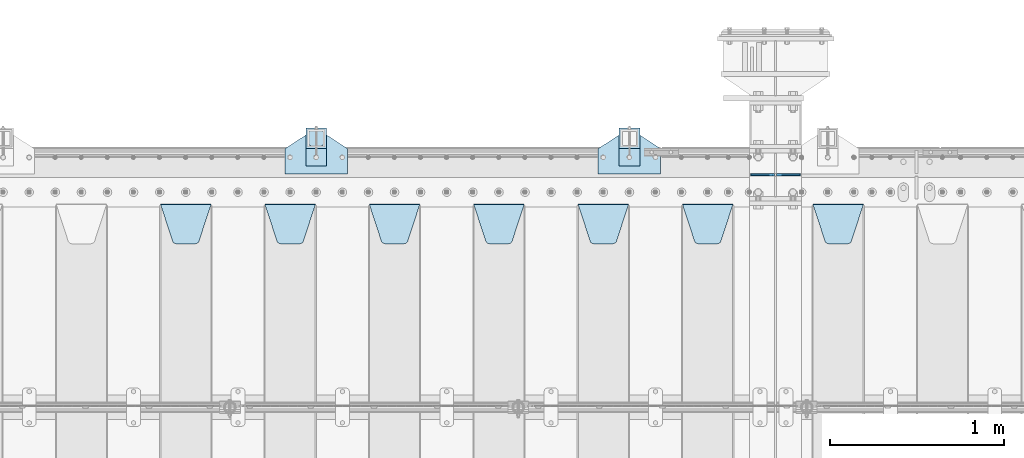
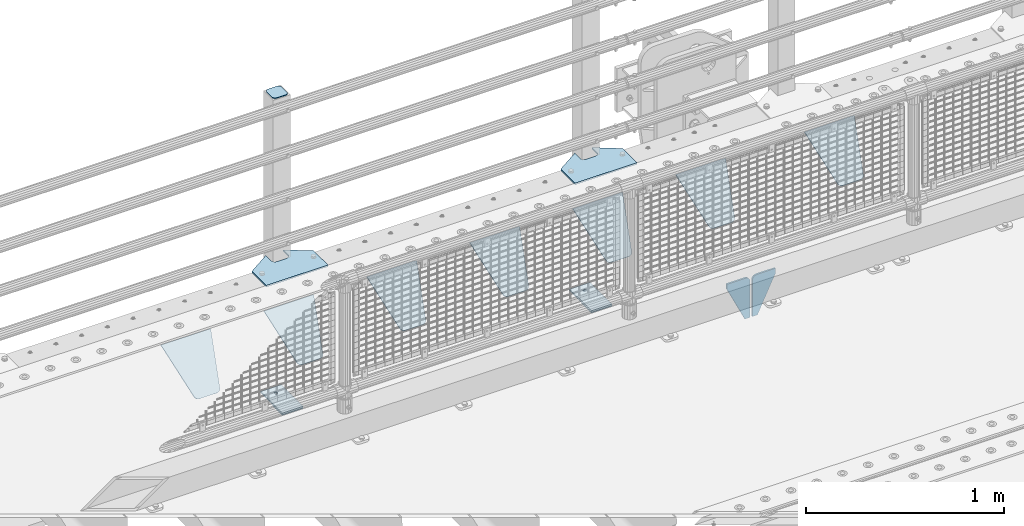
# One storey, part 174 of 193: 16 plates.
"""IFC2X3 building model written with IfcOpenShell, lengths in millimetres."""

from ifc_helpers import new_model, si_unit, frame, origin_with_axes, place, context, subcontext, project, spatial, faceted_brep, material, type_object, element, save


model = new_model("IFC2X3")

# Units and contexts
model_context = context("Model", 3, precision=1e-05, world=origin_with_axes())
body_context = subcontext(model_context, "Body", "Model", "MODEL_VIEW")
ifc_project = project(units=[si_unit("LENGTHUNIT", "METRE", prefix="MILLI"), si_unit("AREAUNIT", "SQUARE_METRE"), si_unit("VOLUMEUNIT", "CUBIC_METRE"), si_unit("MASSUNIT", "GRAM", prefix="KILO"), si_unit("TIMEUNIT", "SECOND"), si_unit("PLANEANGLEUNIT", "RADIAN"), si_unit("SOLIDANGLEUNIT", "STERADIAN"), si_unit("THERMODYNAMICTEMPERATUREUNIT", "DEGREE_CELSIUS"), si_unit("LUMINOUSINTENSITYUNIT", "LUMEN")], contexts=[model_context])

# Site, building, storey
site_placement = place(None, origin_with_axes())
site = spatial("IfcSite", under=ifc_project, at=site_placement, CompositionType="ELEMENT")
building_placement = place(site_placement, origin_with_axes())
building = spatial("IfcBuilding", under=site, at=building_placement, Name="Standard", CompositionType="ELEMENT")
storey_placement = place(building_placement, origin_with_axes())
storey = spatial("IfcBuildingStorey", under=building, at=storey_placement, Name="Undefined", CompositionType="ELEMENT", Elevation=0.0)

# Plates
ifc_material_1 = material(Name="STEEL/S355N")
plate_type_1 = type_object("IfcPlateType", PredefinedType="NOTDEFINED")
for number, where, z_axis, x_axis in (
    (1, (-32066.4999999352, 29999.9999999954, -915.000018206183), (0.0, 0.0, -1.0), (-1.0, 0.0, 0.0)),
    (2, (-32053.4999999352, 29999.9999999954, -915.000018206183), (0.0, 0.0, -1.0), (1.0, 0.0, 0.0)),
):
    element("IfcPlate", number, at=place(storey_placement, frame(where, z_axis=z_axis, x_axis=x_axis)), inside=storey, type_object=plate_type_1, material=ifc_material_1, context=body_context, shape_type="Brep", body=[
        faceted_brep([(0.0, -5.0, 27.0), (0.0, -5.0, 250.0), (0.0, 5.0, 250.0), (0.0, 5.0, 27.0), (30.0, -5.0, 250.0), (30.0, 5.0, 250.0), (135.0, -5.0, 30.0), (135.0, 5.0, 30.0), (135.0, -5.0, 0.0), (135.0, 5.0, 0.0), (27.0, -5.0, 0.0), (27.0, 5.0, 0.0), (22.3114992029914, -5.0, 0.410190668670339), (22.3114992029914, 5.0, 0.410190668670339), (17.7654561302079, -5.0, 1.62829923878041), (17.7654561302079, 5.0, 1.62829923878041), (13.5, -5.0, 3.61731409782021), (13.5, 5.0, 3.61731409782021), (9.64473453846222, -5.0, 6.31680003578765), (9.64473453846222, 5.0, 6.31680003578765), (6.31680003578731, -5.0, 9.64473453846347), (6.31680003578731, 5.0, 9.64473453846347), (3.61731409782078, -5.0, 13.5), (3.61731409782078, 5.0, 13.5), (1.62829923877871, -5.0, 17.765456130207), (1.62829923877871, 5.0, 17.765456130207), (0.410190668670111, -5.0, 22.3114992029929), (0.410190668670111, 5.0, 22.3114992029929)], [[[0, 1, 2, 3]], [[1, 4, 5, 2]], [[4, 6, 7, 5]], [[6, 8, 9, 7]], [[8, 10, 11, 9]], [[10, 12, 13, 11]], [[12, 14, 15, 13]], [[14, 16, 17, 15]], [[16, 18, 19, 17]], [[18, 20, 21, 19]], [[20, 22, 23, 21]], [[22, 24, 25, 23]], [[24, 26, 27, 25]], [[26, 0, 3, 27]], [[5, 7, 9, 11, 13, 15, 17, 19, 21, 23, 25, 27, 3, 2]], [[26, 24, 22, 20, 18, 16, 14, 12, 10, 8, 6, 4, 1, 0]]]),
    ])
plate_type_2 = type_object("IfcPlateType", PredefinedType="NOTDEFINED")
plate_1_placement = place(storey_placement, frame((-31845.0, 29831.767766956, -1.76776695296758), z_axis=(0.0, -0.707106781186547, -0.707106781186548), x_axis=(1.0, 0.0, 0.0)))
element("IfcPlate", 3, at=plate_1_placement, inside=storey, type_object=plate_type_2, material=ifc_material_1, context=body_context, shape_type="Brep", body=[
    faceted_brep([(0.0, -2.5, 0.0), (69.345504679477, -2.50000000000364, 300.171731424831), (69.345504679477, 2.49999999999636, 300.171731424831), (0.0, 2.5, 0.0), (70.9274061199576, -2.50000000000364, 304.897442415397), (70.9274061199576, 2.49999999999636, 304.897442415397), (73.3818627772307, -2.50000000000364, 309.234538108529), (73.3818627772307, 2.49999999999636, 309.234538108529), (76.6187032999551, -2.50000000000728, 313.023683126103), (76.6187032999551, 2.49999999999636, 313.023683126103), (80.5190132704993, -2.50000000000364, 316.125672595372), (80.5190132704993, 2.49999999999636, 316.125672595368), (84.9395038596849, -2.50000000000364, 318.426546230472), (84.9395038596849, 2.49999999999636, 318.426546230476), (89.7177759439219, -2.50000000000364, 319.841774983273), (89.7177759439219, 2.49999999999636, 319.841774983277), (94.678286292652, -2.50000000000364, 320.319366455074), (94.678286292652, 2.49999999999636, 320.319366455074), (195.321713707348, -2.50000000000364, 320.319366455074), (195.321713707348, 2.49999999999636, 320.319366455074), (200.282224056078, -2.50000000000364, 319.841774983273), (200.282224056078, 2.49999999999636, 319.841774983277), (205.060496140315, -2.50000000000364, 318.426546230472), (205.060496140315, 2.49999999999636, 318.426546230472), (209.480986729501, -2.50000000000364, 316.125672595372), (209.480986729501, 2.49999999999636, 316.125672595368), (213.381296700045, -2.50000000000728, 313.023683126103), (213.381296700045, 2.49999999999272, 313.023683126103), (216.618137222769, -2.50000000000364, 309.234538108525), (216.618137222769, 2.49999999999636, 309.234538108522), (219.072593880042, -2.50000000000364, 304.897442415397), (219.072593880042, 2.49999999999636, 304.897442415397), (220.654495320523, -2.50000000000364, 300.171731424831), (220.654495320523, 2.49999999999636, 300.171731424831), (290.0, -2.50000000000364, 0.0), (290.0, 2.49999999999636, 0.0)], [[[0, 1, 2, 3]], [[1, 4, 5, 2]], [[4, 6, 7, 5]], [[6, 8, 9, 7]], [[8, 10, 11, 9]], [[10, 12, 13, 11]], [[12, 14, 15, 13]], [[14, 16, 17, 15]], [[16, 18, 19, 17]], [[18, 20, 21, 19]], [[20, 22, 23, 21]], [[22, 24, 25, 23]], [[24, 26, 27, 25]], [[26, 28, 29, 27]], [[28, 30, 31, 29]], [[30, 32, 33, 31]], [[32, 34, 35, 33]], [[34, 0, 3, 35]], [[5, 7, 9, 11, 13, 15, 17, 19, 21, 23, 25, 27, 29, 31, 33, 35, 3, 2]], [[34, 32, 30, 28, 26, 24, 22, 20, 18, 16, 14, 12, 10, 8, 6, 4, 1, 0]]]),
])
plate_2_placement = place(storey_placement, frame((-32595.0, 29831.767766956, -1.76776695296758), z_axis=(0.0, -0.707106781186547, -0.707106781186548), x_axis=(1.0, 0.0, 0.0)))
element("IfcPlate", 4, at=plate_2_placement, inside=storey, type_object=plate_type_2, material=ifc_material_1, context=body_context, shape_type="Brep", body=[
    faceted_brep([(0.0, -2.5, 0.0), (69.345504679477, -2.50000000000364, 300.171731424831), (69.345504679477, 2.49999999999636, 300.171731424831), (0.0, 2.5, 0.0), (70.9274061199576, -2.50000000000364, 304.897442415397), (70.9274061199576, 2.49999999999636, 304.897442415397), (73.3818627772307, -2.50000000000364, 309.234538108529), (73.3818627772307, 2.49999999999636, 309.234538108529), (76.6187032999551, -2.50000000000728, 313.023683126103), (76.6187032999551, 2.49999999999636, 313.023683126103), (80.5190132704993, -2.50000000000364, 316.125672595372), (80.5190132704993, 2.49999999999636, 316.125672595368), (84.9395038596849, -2.50000000000364, 318.426546230472), (84.9395038596849, 2.49999999999636, 318.426546230476), (89.7177759439219, -2.50000000000364, 319.841774983273), (89.7177759439219, 2.49999999999636, 319.841774983277), (94.678286292652, -2.50000000000364, 320.319366455074), (94.678286292652, 2.49999999999636, 320.319366455074), (195.321713707348, -2.50000000000364, 320.319366455074), (195.321713707348, 2.49999999999636, 320.319366455074), (200.282224056078, -2.50000000000364, 319.841774983273), (200.282224056078, 2.49999999999636, 319.841774983277), (205.060496140315, -2.50000000000364, 318.426546230472), (205.060496140315, 2.49999999999636, 318.426546230472), (209.480986729501, -2.50000000000364, 316.125672595372), (209.480986729501, 2.49999999999636, 316.125672595368), (213.381296700045, -2.50000000000728, 313.023683126103), (213.381296700045, 2.49999999999272, 313.023683126103), (216.618137222769, -2.50000000000364, 309.234538108525), (216.618137222769, 2.49999999999636, 309.234538108522), (219.072593880042, -2.50000000000364, 304.897442415397), (219.072593880042, 2.49999999999636, 304.897442415397), (220.654495320523, -2.50000000000364, 300.171731424831), (220.654495320523, 2.49999999999636, 300.171731424831), (290.0, -2.50000000000364, 0.0), (290.0, 2.49999999999636, 0.0)], [[[0, 1, 2, 3]], [[1, 4, 5, 2]], [[4, 6, 7, 5]], [[6, 8, 9, 7]], [[8, 10, 11, 9]], [[10, 12, 13, 11]], [[12, 14, 15, 13]], [[14, 16, 17, 15]], [[16, 18, 19, 17]], [[18, 20, 21, 19]], [[20, 22, 23, 21]], [[22, 24, 25, 23]], [[24, 26, 27, 25]], [[26, 28, 29, 27]], [[28, 30, 31, 29]], [[30, 32, 33, 31]], [[32, 34, 35, 33]], [[34, 0, 3, 35]], [[5, 7, 9, 11, 13, 15, 17, 19, 21, 23, 25, 27, 29, 31, 33, 35, 3, 2]], [[34, 32, 30, 28, 26, 24, 22, 20, 18, 16, 14, 12, 10, 8, 6, 4, 1, 0]]]),
])
plate_3_placement = place(storey_placement, frame((-33195.0, 29831.767766956, -1.76776695296758), z_axis=(0.0, -0.707106781186547, -0.707106781186548), x_axis=(1.0, 0.0, 0.0)))
element("IfcPlate", 5, at=plate_3_placement, inside=storey, type_object=plate_type_2, material=ifc_material_1, context=body_context, shape_type="Brep", body=[
    faceted_brep([(0.0, -2.5, 0.0), (69.345504679477, -2.50000000000364, 300.171731424831), (69.345504679477, 2.49999999999636, 300.171731424831), (0.0, 2.5, 0.0), (70.9274061199576, -2.50000000000364, 304.897442415397), (70.9274061199576, 2.49999999999636, 304.897442415397), (73.3818627772307, -2.50000000000364, 309.234538108529), (73.3818627772307, 2.49999999999636, 309.234538108529), (76.6187032999551, -2.50000000000728, 313.023683126103), (76.6187032999551, 2.49999999999636, 313.023683126103), (80.5190132704993, -2.50000000000364, 316.125672595372), (80.5190132704993, 2.49999999999636, 316.125672595368), (84.9395038596849, -2.50000000000364, 318.426546230472), (84.9395038596849, 2.49999999999636, 318.426546230476), (89.7177759439219, -2.50000000000364, 319.841774983273), (89.7177759439219, 2.49999999999636, 319.841774983277), (94.678286292652, -2.50000000000364, 320.319366455074), (94.678286292652, 2.49999999999636, 320.319366455074), (195.321713707348, -2.50000000000364, 320.319366455074), (195.321713707348, 2.49999999999636, 320.319366455074), (200.282224056078, -2.50000000000364, 319.841774983273), (200.282224056078, 2.49999999999636, 319.841774983277), (205.060496140315, -2.50000000000364, 318.426546230472), (205.060496140315, 2.49999999999636, 318.426546230472), (209.480986729501, -2.50000000000364, 316.125672595372), (209.480986729501, 2.49999999999636, 316.125672595368), (213.381296700045, -2.50000000000728, 313.023683126103), (213.381296700045, 2.49999999999272, 313.023683126103), (216.618137222769, -2.50000000000364, 309.234538108525), (216.618137222769, 2.49999999999636, 309.234538108522), (219.072593880042, -2.50000000000364, 304.897442415397), (219.072593880042, 2.49999999999636, 304.897442415397), (220.654495320523, -2.50000000000364, 300.171731424831), (220.654495320523, 2.49999999999636, 300.171731424831), (290.0, -2.50000000000364, 0.0), (290.0, 2.49999999999636, 0.0)], [[[0, 1, 2, 3]], [[1, 4, 5, 2]], [[4, 6, 7, 5]], [[6, 8, 9, 7]], [[8, 10, 11, 9]], [[10, 12, 13, 11]], [[12, 14, 15, 13]], [[14, 16, 17, 15]], [[16, 18, 19, 17]], [[18, 20, 21, 19]], [[20, 22, 23, 21]], [[22, 24, 25, 23]], [[24, 26, 27, 25]], [[26, 28, 29, 27]], [[28, 30, 31, 29]], [[30, 32, 33, 31]], [[32, 34, 35, 33]], [[34, 0, 3, 35]], [[5, 7, 9, 11, 13, 15, 17, 19, 21, 23, 25, 27, 29, 31, 33, 35, 3, 2]], [[34, 32, 30, 28, 26, 24, 22, 20, 18, 16, 14, 12, 10, 8, 6, 4, 1, 0]]]),
])
plate_4_placement = place(storey_placement, frame((-33795.0, 29831.767766956, -1.76776695296758), z_axis=(0.0, -0.707106781186547, -0.707106781186548), x_axis=(1.0, 0.0, 0.0)))
element("IfcPlate", 6, at=plate_4_placement, inside=storey, type_object=plate_type_2, material=ifc_material_1, context=body_context, shape_type="Brep", body=[
    faceted_brep([(0.0, -2.5, 0.0), (69.345504679477, -2.50000000000364, 300.171731424831), (69.345504679477, 2.49999999999636, 300.171731424831), (0.0, 2.5, 0.0), (70.9274061199576, -2.50000000000364, 304.897442415397), (70.9274061199576, 2.49999999999636, 304.897442415397), (73.3818627772307, -2.50000000000364, 309.234538108529), (73.3818627772307, 2.49999999999636, 309.234538108529), (76.6187032999551, -2.50000000000728, 313.023683126103), (76.6187032999551, 2.49999999999636, 313.023683126103), (80.5190132704993, -2.50000000000364, 316.125672595372), (80.5190132704993, 2.49999999999636, 316.125672595368), (84.9395038596849, -2.50000000000364, 318.426546230472), (84.9395038596849, 2.49999999999636, 318.426546230476), (89.7177759439219, -2.50000000000364, 319.841774983273), (89.7177759439219, 2.49999999999636, 319.841774983277), (94.678286292652, -2.50000000000364, 320.319366455074), (94.678286292652, 2.49999999999636, 320.319366455074), (195.321713707348, -2.50000000000364, 320.319366455074), (195.321713707348, 2.49999999999636, 320.319366455074), (200.282224056078, -2.50000000000364, 319.841774983273), (200.282224056078, 2.49999999999636, 319.841774983277), (205.060496140315, -2.50000000000364, 318.426546230472), (205.060496140315, 2.49999999999636, 318.426546230472), (209.480986729501, -2.50000000000364, 316.125672595372), (209.480986729501, 2.49999999999636, 316.125672595368), (213.381296700045, -2.50000000000728, 313.023683126103), (213.381296700045, 2.49999999999272, 313.023683126103), (216.618137222769, -2.50000000000364, 309.234538108525), (216.618137222769, 2.49999999999636, 309.234538108522), (219.072593880042, -2.50000000000364, 304.897442415397), (219.072593880042, 2.49999999999636, 304.897442415397), (220.654495320523, -2.50000000000364, 300.171731424831), (220.654495320523, 2.49999999999636, 300.171731424831), (290.0, -2.50000000000364, 0.0), (290.0, 2.49999999999636, 0.0)], [[[0, 1, 2, 3]], [[1, 4, 5, 2]], [[4, 6, 7, 5]], [[6, 8, 9, 7]], [[8, 10, 11, 9]], [[10, 12, 13, 11]], [[12, 14, 15, 13]], [[14, 16, 17, 15]], [[16, 18, 19, 17]], [[18, 20, 21, 19]], [[20, 22, 23, 21]], [[22, 24, 25, 23]], [[24, 26, 27, 25]], [[26, 28, 29, 27]], [[28, 30, 31, 29]], [[30, 32, 33, 31]], [[32, 34, 35, 33]], [[34, 0, 3, 35]], [[5, 7, 9, 11, 13, 15, 17, 19, 21, 23, 25, 27, 29, 31, 33, 35, 3, 2]], [[34, 32, 30, 28, 26, 24, 22, 20, 18, 16, 14, 12, 10, 8, 6, 4, 1, 0]]]),
])
plate_5_placement = place(storey_placement, frame((-34395.0, 29831.767766956, -1.76776695296758), z_axis=(0.0, -0.707106781186547, -0.707106781186548), x_axis=(1.0, 0.0, 0.0)))
element("IfcPlate", 7, at=plate_5_placement, inside=storey, type_object=plate_type_2, material=ifc_material_1, context=body_context, shape_type="Brep", body=[
    faceted_brep([(0.0, -2.5, 0.0), (69.345504679477, -2.50000000000364, 300.171731424831), (69.345504679477, 2.49999999999636, 300.171731424831), (0.0, 2.5, 0.0), (70.9274061199576, -2.50000000000364, 304.897442415397), (70.9274061199576, 2.49999999999636, 304.897442415397), (73.3818627772307, -2.50000000000364, 309.234538108529), (73.3818627772307, 2.49999999999636, 309.234538108529), (76.6187032999551, -2.50000000000728, 313.023683126103), (76.6187032999551, 2.49999999999636, 313.023683126103), (80.5190132704993, -2.50000000000364, 316.125672595372), (80.5190132704993, 2.49999999999636, 316.125672595368), (84.9395038596849, -2.50000000000364, 318.426546230472), (84.9395038596849, 2.49999999999636, 318.426546230476), (89.7177759439219, -2.50000000000364, 319.841774983273), (89.7177759439219, 2.49999999999636, 319.841774983277), (94.678286292652, -2.50000000000364, 320.319366455074), (94.678286292652, 2.49999999999636, 320.319366455074), (195.321713707348, -2.50000000000364, 320.319366455074), (195.321713707348, 2.49999999999636, 320.319366455074), (200.282224056078, -2.50000000000364, 319.841774983273), (200.282224056078, 2.49999999999636, 319.841774983277), (205.060496140315, -2.50000000000364, 318.426546230472), (205.060496140315, 2.49999999999636, 318.426546230472), (209.480986729501, -2.50000000000364, 316.125672595372), (209.480986729501, 2.49999999999636, 316.125672595368), (213.381296700045, -2.50000000000728, 313.023683126103), (213.381296700045, 2.49999999999272, 313.023683126103), (216.618137222769, -2.50000000000364, 309.234538108525), (216.618137222769, 2.49999999999636, 309.234538108522), (219.072593880042, -2.50000000000364, 304.897442415397), (219.072593880042, 2.49999999999636, 304.897442415397), (220.654495320523, -2.50000000000364, 300.171731424831), (220.654495320523, 2.49999999999636, 300.171731424831), (290.0, -2.50000000000364, 0.0), (290.0, 2.49999999999636, 0.0)], [[[0, 1, 2, 3]], [[1, 4, 5, 2]], [[4, 6, 7, 5]], [[6, 8, 9, 7]], [[8, 10, 11, 9]], [[10, 12, 13, 11]], [[12, 14, 15, 13]], [[14, 16, 17, 15]], [[16, 18, 19, 17]], [[18, 20, 21, 19]], [[20, 22, 23, 21]], [[22, 24, 25, 23]], [[24, 26, 27, 25]], [[26, 28, 29, 27]], [[28, 30, 31, 29]], [[30, 32, 33, 31]], [[32, 34, 35, 33]], [[34, 0, 3, 35]], [[5, 7, 9, 11, 13, 15, 17, 19, 21, 23, 25, 27, 29, 31, 33, 35, 3, 2]], [[34, 32, 30, 28, 26, 24, 22, 20, 18, 16, 14, 12, 10, 8, 6, 4, 1, 0]]]),
])
plate_6_placement = place(storey_placement, frame((-34995.0, 29831.767766956, -1.76776695296758), z_axis=(0.0, -0.707106781186547, -0.707106781186548), x_axis=(1.0, 0.0, 0.0)))
element("IfcPlate", 8, at=plate_6_placement, inside=storey, type_object=plate_type_2, material=ifc_material_1, context=body_context, shape_type="Brep", body=[
    faceted_brep([(0.0, -2.5, 0.0), (69.345504679477, -2.50000000000364, 300.171731424831), (69.345504679477, 2.49999999999636, 300.171731424831), (0.0, 2.5, 0.0), (70.9274061199576, -2.50000000000364, 304.897442415397), (70.9274061199576, 2.49999999999636, 304.897442415397), (73.3818627772307, -2.50000000000364, 309.234538108529), (73.3818627772307, 2.49999999999636, 309.234538108529), (76.6187032999551, -2.50000000000728, 313.023683126103), (76.6187032999551, 2.49999999999636, 313.023683126103), (80.5190132704993, -2.50000000000364, 316.125672595372), (80.5190132704993, 2.49999999999636, 316.125672595368), (84.9395038596849, -2.50000000000364, 318.426546230472), (84.9395038596849, 2.49999999999636, 318.426546230476), (89.7177759439219, -2.50000000000364, 319.841774983273), (89.7177759439219, 2.49999999999636, 319.841774983277), (94.678286292652, -2.50000000000364, 320.319366455074), (94.678286292652, 2.49999999999636, 320.319366455074), (195.321713707348, -2.50000000000364, 320.319366455074), (195.321713707348, 2.49999999999636, 320.319366455074), (200.282224056078, -2.50000000000364, 319.841774983273), (200.282224056078, 2.49999999999636, 319.841774983277), (205.060496140315, -2.50000000000364, 318.426546230472), (205.060496140315, 2.49999999999636, 318.426546230472), (209.480986729501, -2.50000000000364, 316.125672595372), (209.480986729501, 2.49999999999636, 316.125672595368), (213.381296700045, -2.50000000000728, 313.023683126103), (213.381296700045, 2.49999999999272, 313.023683126103), (216.618137222769, -2.50000000000364, 309.234538108525), (216.618137222769, 2.49999999999636, 309.234538108522), (219.072593880042, -2.50000000000364, 304.897442415397), (219.072593880042, 2.49999999999636, 304.897442415397), (220.654495320523, -2.50000000000364, 300.171731424831), (220.654495320523, 2.49999999999636, 300.171731424831), (290.0, -2.50000000000364, 0.0), (290.0, 2.49999999999636, 0.0)], [[[0, 1, 2, 3]], [[1, 4, 5, 2]], [[4, 6, 7, 5]], [[6, 8, 9, 7]], [[8, 10, 11, 9]], [[10, 12, 13, 11]], [[12, 14, 15, 13]], [[14, 16, 17, 15]], [[16, 18, 19, 17]], [[18, 20, 21, 19]], [[20, 22, 23, 21]], [[22, 24, 25, 23]], [[24, 26, 27, 25]], [[26, 28, 29, 27]], [[28, 30, 31, 29]], [[30, 32, 33, 31]], [[32, 34, 35, 33]], [[34, 0, 3, 35]], [[5, 7, 9, 11, 13, 15, 17, 19, 21, 23, 25, 27, 29, 31, 33, 35, 3, 2]], [[34, 32, 30, 28, 26, 24, 22, 20, 18, 16, 14, 12, 10, 8, 6, 4, 1, 0]]]),
])
plate_7_placement = place(storey_placement, frame((-35595.0, 29831.767766956, -1.76776695296758), z_axis=(0.0, -0.707106781186547, -0.707106781186548), x_axis=(1.0, 0.0, 0.0)))
element("IfcPlate", 9, at=plate_7_placement, inside=storey, type_object=plate_type_2, material=ifc_material_1, context=body_context, shape_type="Brep", body=[
    faceted_brep([(0.0, -2.5, 0.0), (69.345504679477, -2.50000000000364, 300.171731424831), (69.345504679477, 2.49999999999636, 300.171731424831), (0.0, 2.5, 0.0), (70.9274061199576, -2.50000000000364, 304.897442415397), (70.9274061199576, 2.49999999999636, 304.897442415397), (73.3818627772307, -2.50000000000364, 309.234538108529), (73.3818627772307, 2.49999999999636, 309.234538108529), (76.6187032999551, -2.50000000000728, 313.023683126103), (76.6187032999551, 2.49999999999636, 313.023683126103), (80.5190132704993, -2.50000000000364, 316.125672595372), (80.5190132704993, 2.49999999999636, 316.125672595368), (84.9395038596849, -2.50000000000364, 318.426546230472), (84.9395038596849, 2.49999999999636, 318.426546230476), (89.7177759439219, -2.50000000000364, 319.841774983273), (89.7177759439219, 2.49999999999636, 319.841774983277), (94.678286292652, -2.50000000000364, 320.319366455074), (94.678286292652, 2.49999999999636, 320.319366455074), (195.321713707348, -2.50000000000364, 320.319366455074), (195.321713707348, 2.49999999999636, 320.319366455074), (200.282224056078, -2.50000000000364, 319.841774983273), (200.282224056078, 2.49999999999636, 319.841774983277), (205.060496140315, -2.50000000000364, 318.426546230472), (205.060496140315, 2.49999999999636, 318.426546230472), (209.480986729501, -2.50000000000364, 316.125672595372), (209.480986729501, 2.49999999999636, 316.125672595368), (213.381296700045, -2.50000000000728, 313.023683126103), (213.381296700045, 2.49999999999272, 313.023683126103), (216.618137222769, -2.50000000000364, 309.234538108525), (216.618137222769, 2.49999999999636, 309.234538108522), (219.072593880042, -2.50000000000364, 304.897442415397), (219.072593880042, 2.49999999999636, 304.897442415397), (220.654495320523, -2.50000000000364, 300.171731424831), (220.654495320523, 2.49999999999636, 300.171731424831), (290.0, -2.50000000000364, 0.0), (290.0, 2.49999999999636, 0.0)], [[[0, 1, 2, 3]], [[1, 4, 5, 2]], [[4, 6, 7, 5]], [[6, 8, 9, 7]], [[8, 10, 11, 9]], [[10, 12, 13, 11]], [[12, 14, 15, 13]], [[14, 16, 17, 15]], [[16, 18, 19, 17]], [[18, 20, 21, 19]], [[20, 22, 23, 21]], [[22, 24, 25, 23]], [[24, 26, 27, 25]], [[26, 28, 29, 27]], [[28, 30, 31, 29]], [[30, 32, 33, 31]], [[32, 34, 35, 33]], [[34, 0, 3, 35]], [[5, 7, 9, 11, 13, 15, 17, 19, 21, 23, 25, 27, 29, 31, 33, 35, 3, 2]], [[34, 32, 30, 28, 26, 24, 22, 20, 18, 16, 14, 12, 10, 8, 6, 4, 1, 0]]]),
])
ifc_material_2 = material(Name="STEEL/S355J2")
plate_type_3 = type_object("IfcPlateType", PredefinedType="NOTDEFINED")
plate_8_placement = place(storey_placement, frame((-33080.0, 30005.0, 5.00000000004911), z_axis=(0.0, 1.0, 0.0), x_axis=(1.0, 0.0, 0.0)))
element("IfcPlate", 10, at=plate_8_placement, inside=storey, type_object=plate_type_3, material=ifc_material_2, context=body_context, shape_type="Brep", body=[
    faceted_brep([(0.0, -5.0, 0.0), (2.31396552408114e-06, -5.0, 145.0), (2.31396552408114e-06, 5.0, 145.0), (0.0, 5.0, 0.0), (130.0, -5.0, 230.0), (130.0, 5.0, 230.0), (130.0, -5.0, 180.0), (130.0, 5.0, 180.0), (130.48036798992, -5.0, 175.122741949595), (130.48036798992, 5.0, 175.122741949595), (131.903011687216, -5.0, 170.432914190871), (131.903011687216, 5.0, 170.432914190871), (134.213259692435, -5.0, 166.110744174512), (134.213259692435, 5.0, 166.110744174512), (137.322330470335, -5.0, 162.322330470335), (137.322330470335, 5.0, 162.322330470335), (141.110744174512, -5.0, 159.213259692435), (141.110744174512, 5.0, 159.213259692435), (145.432914190871, -5.0, 156.903011687216), (145.432914190871, 5.0, 156.903011687216), (150.122741949595, -5.0, 155.48036798992), (150.122741949595, 5.0, 155.48036798992), (155.0, -5.0, 155.0), (155.0, 5.0, 155.0), (205.0, -5.0, 155.0), (205.0, 5.0, 155.0), (209.877258050405, -5.0, 155.48036798992), (209.877258050405, 5.0, 155.48036798992), (214.567085809129, -5.0, 156.903011687216), (214.567085809129, 5.0, 156.903011687216), (218.889255825488, -5.0, 159.213259692435), (218.889255825488, 5.0, 159.213259692435), (222.677669529665, -5.0, 162.322330470335), (222.677669529665, 5.0, 162.322330470335), (225.786740307565, -5.0, 166.110744174512), (225.786740307565, 5.0, 166.110744174512), (228.096988312784, -5.0, 170.432914190871), (228.096988312784, 5.0, 170.432914190871), (229.51963201008, -5.0, 175.122741949595), (229.51963201008, 5.0, 175.122741949595), (230.0, -5.0, 180.0), (230.0, 5.0, 180.0), (230.0, -5.0, 230.0), (230.0, 5.0, 230.0), (360.0, -5.0, 145.0), (360.0, 5.0, 145.0), (360.0, -5.0, -7.27595761418343e-12), (360.0, 5.0, -7.27595761418343e-12)], [[[0, 1, 2, 3]], [[1, 4, 5, 2]], [[4, 6, 7, 5]], [[6, 8, 9, 7]], [[8, 10, 11, 9]], [[10, 12, 13, 11]], [[12, 14, 15, 13]], [[14, 16, 17, 15]], [[16, 18, 19, 17]], [[18, 20, 21, 19]], [[20, 22, 23, 21]], [[22, 24, 25, 23]], [[24, 26, 27, 25]], [[26, 28, 29, 27]], [[28, 30, 31, 29]], [[30, 32, 33, 31]], [[32, 34, 35, 33]], [[34, 36, 37, 35]], [[36, 38, 39, 37]], [[38, 40, 41, 39]], [[40, 42, 43, 41]], [[42, 44, 45, 43]], [[44, 46, 47, 45]], [[46, 0, 3, 47]], [[5, 7, 9, 11, 13, 15, 17, 19, 21, 23, 25, 27, 29, 31, 33, 35, 37, 39, 41, 43, 45, 47, 3, 2]], [[46, 44, 42, 40, 38, 36, 34, 32, 30, 28, 26, 24, 22, 20, 18, 16, 14, 12, 10, 8, 6, 4, 1, 0]]]),
])
plate_9_placement = place(storey_placement, frame((-34880.0, 30005.0, 5.00000000004911), z_axis=(0.0, 1.0, 0.0), x_axis=(1.0, 0.0, 0.0)))
element("IfcPlate", 11, at=plate_9_placement, inside=storey, type_object=plate_type_3, material=ifc_material_2, context=body_context, shape_type="Brep", body=[
    faceted_brep([(0.0, -5.0, 0.0), (2.31396552408114e-06, -5.0, 145.0), (2.31396552408114e-06, 5.0, 145.0), (0.0, 5.0, 0.0), (130.0, -5.0, 230.0), (130.0, 5.0, 230.0), (130.0, -5.0, 180.0), (130.0, 5.0, 180.0), (130.48036798992, -5.0, 175.122741949595), (130.48036798992, 5.0, 175.122741949595), (131.903011687216, -5.0, 170.432914190871), (131.903011687216, 5.0, 170.432914190871), (134.213259692435, -5.0, 166.110744174512), (134.213259692435, 5.0, 166.110744174512), (137.322330470335, -5.0, 162.322330470335), (137.322330470335, 5.0, 162.322330470335), (141.110744174512, -5.0, 159.213259692435), (141.110744174512, 5.0, 159.213259692435), (145.432914190871, -5.0, 156.903011687216), (145.432914190871, 5.0, 156.903011687216), (150.122741949595, -5.0, 155.48036798992), (150.122741949595, 5.0, 155.48036798992), (155.0, -5.0, 155.0), (155.0, 5.0, 155.0), (205.0, -5.0, 155.0), (205.0, 5.0, 155.0), (209.877258050405, -5.0, 155.48036798992), (209.877258050405, 5.0, 155.48036798992), (214.567085809129, -5.0, 156.903011687216), (214.567085809129, 5.0, 156.903011687216), (218.889255825488, -5.0, 159.213259692435), (218.889255825488, 5.0, 159.213259692435), (222.677669529665, -5.0, 162.322330470335), (222.677669529665, 5.0, 162.322330470335), (225.786740307565, -5.0, 166.110744174512), (225.786740307565, 5.0, 166.110744174512), (228.096988312784, -5.0, 170.432914190871), (228.096988312784, 5.0, 170.432914190871), (229.51963201008, -5.0, 175.122741949595), (229.51963201008, 5.0, 175.122741949595), (230.0, -5.0, 180.0), (230.0, 5.0, 180.0), (230.0, -5.0, 230.0), (230.0, 5.0, 230.0), (360.0, -5.0, 145.0), (360.0, 5.0, 145.0), (360.0, -5.0, -7.27595761418343e-12), (360.0, 5.0, -7.27595761418343e-12)], [[[0, 1, 2, 3]], [[1, 4, 5, 2]], [[4, 6, 7, 5]], [[6, 8, 9, 7]], [[8, 10, 11, 9]], [[10, 12, 13, 11]], [[12, 14, 15, 13]], [[14, 16, 17, 15]], [[16, 18, 19, 17]], [[18, 20, 21, 19]], [[20, 22, 23, 21]], [[22, 24, 25, 23]], [[24, 26, 27, 25]], [[26, 28, 29, 27]], [[28, 30, 31, 29]], [[30, 32, 33, 31]], [[32, 34, 35, 33]], [[34, 36, 37, 35]], [[36, 38, 39, 37]], [[38, 40, 41, 39]], [[40, 42, 43, 41]], [[42, 44, 45, 43]], [[44, 46, 47, 45]], [[46, 0, 3, 47]], [[5, 7, 9, 11, 13, 15, 17, 19, 21, 23, 25, 27, 29, 31, 33, 35, 37, 39, 41, 43, 45, 47, 3, 2]], [[46, 44, 42, 40, 38, 36, 34, 32, 30, 28, 26, 24, 22, 20, 18, 16, 14, 12, 10, 8, 6, 4, 1, 0]]]),
])
plate_type_4 = type_object("IfcPlateType", PredefinedType="NOTDEFINED")
for number, where, z_axis, x_axis in (
    (12, (-32959.9999999999, 30050.0000000002, -850.000000000002), (0.0, 1.0, 0.0), (1.0, 0.0, 0.0)),
    (13, (-34759.9999999999, 30050.0000000002, -850.000000000002), (0.0, 1.0, 0.0), (1.0, 0.0, 0.0)),
):
    element("IfcPlate", number, at=place(storey_placement, frame(where, z_axis=z_axis, x_axis=x_axis)), inside=storey, type_object=plate_type_4, material=ifc_material_2, context=body_context, shape_type="Brep", body=[
        faceted_brep([(66.3639610305399, -5.0, 163.636038969111), (66.3639610305399, 5.0, 163.636038969111), (59.9999999998618, 5.0, 160.999999999789), (59.9999999998618, -5.0, 160.999999999789), (53.6360389691836, 5.0, 163.636038969111), (53.6360389691836, -5.0, 163.636038969111), (50.9999999998618, 5.0, 169.999999999789), (50.9999999998618, -5.0, 169.999999999789), (53.6360389691836, 5.0, 176.363961030467), (53.6360389691836, -5.0, 176.363961030467), (59.9999999998618, 5.0, 178.999999999789), (59.9999999998618, -5.0, 178.999999999789), (66.3639610305399, 5.0, 176.363961030467), (66.3639610305399, -5.0, 176.363961030467), (68.9999999998618, 5.0, 169.999999999789), (68.9999999998618, -5.0, 169.999999999789), (120.0, -5.0, 0.0), (120.0, -5.0, 220.0), (0.0, -5.0, 220.0), (0.0, -5.0, 0.0), (0.0, 5.0, 0.0), (120.0, 5.0, 0.0), (120.0, 5.0, 220.0), (0.0, 5.0, 220.0)], [[[0, 1, 2, 3]], [[3, 2, 4, 5]], [[5, 4, 6, 7]], [[7, 6, 8, 9]], [[9, 8, 10, 11]], [[11, 10, 12, 13]], [[13, 12, 14, 15]], [[15, 14, 1, 0]], [[16, 17, 18, 19], [3, 5, 7, 9, 11, 13, 15, 0]], [[16, 19, 20, 21]], [[17, 16, 21, 22]], [[18, 17, 22, 23]], [[19, 18, 23, 20]], [[22, 21, 20, 23], [10, 8, 6, 4, 2, 1, 14, 12]]]),
    ])
plate_type_5 = type_object("IfcPlateType", PredefinedType="NOTDEFINED")
plate_10_placement = place(storey_placement, frame((-34655.9999999999, 30166.0000000002, 1012.50000000001), z_axis=(0.0, 1.0, 0.0), x_axis=(-1.0, 0.0, 0.0)))
element("IfcPlate", 14, at=plate_10_placement, inside=storey, type_object=plate_type_5, material=ifc_material_2, context=body_context, shape_type="Brep", body=[
    faceted_brep([(0.0, -2.5, 19.0), (0.0, -2.5, 69.0), (0.0, 2.5, 69.0), (0.0, 2.5, 19.0), (0.476369668544066, -2.5, 73.2278977451715), (0.476369668544066, 2.5, 73.2278977451715), (1.88159150985302, -2.5, 77.2437910432345), (1.88159150985302, 2.5, 77.2437910432345), (4.14520183310742, -2.5, 80.8463062353148), (4.14520183310742, 2.5, 80.8463062353148), (7.15369376468516, -2.5, 83.8547981668926), (7.15369376468516, 2.5, 83.8547981668926), (10.7562089567655, -2.5, 86.118408490147), (10.7562089567655, 2.5, 86.118408490147), (14.7721022548285, -2.5, 87.5236303314559), (14.7721022548285, 2.5, 87.5236303314559), (19.0, -2.5, 88.0), (19.0, 2.5, 88.0), (69.0, -2.5, 88.0), (69.0, 2.5, 88.0), (73.2278977451715, -2.5, 87.5236303314559), (73.2278977451715, 2.5, 87.5236303314559), (77.2437910432345, -2.5, 86.118408490147), (77.2437910432345, 2.5, 86.118408490147), (80.8463062353148, -2.5, 83.8547981668926), (80.8463062353148, 2.5, 83.8547981668926), (83.8547981668926, -2.5, 80.8463062353148), (83.8547981668926, 2.5, 80.8463062353148), (86.118408490147, -2.5, 77.2437910432345), (86.118408490147, 2.5, 77.2437910432345), (87.5236303314559, -2.5, 73.2278977451715), (87.5236303314559, 2.5, 73.2278977451715), (88.0, -2.5, 69.0), (88.0, 2.5, 69.0), (88.0, -2.5, 19.0), (88.0, 2.5, 19.0), (87.5236303314559, -2.5, 14.7721022548285), (87.5236303314559, 2.5, 14.7721022548285), (86.118408490147, -2.5, 10.7562089567655), (86.118408490147, 2.5, 10.7562089567655), (83.8547981668926, -2.5, 7.15369376468516), (83.8547981668926, 2.5, 7.15369376468516), (80.8463062353148, -2.5, 4.14520183310742), (80.8463062353148, 2.5, 4.14520183310742), (77.2437910432345, -2.5, 1.88159150985302), (77.2437910432345, 2.5, 1.88159150985302), (73.2278977451715, -2.5, 0.476369668544066), (73.2278977451715, 2.5, 0.476369668544066), (69.0, -2.5, 0.0), (69.0, 2.5, 0.0), (19.0, -2.5, 0.0), (19.0, 2.5, 0.0), (14.7721022548285, -2.5, 0.476369668544066), (14.7721022548285, 2.5, 0.476369668544066), (10.7562089567655, -2.5, 1.88159150985302), (10.7562089567655, 2.5, 1.88159150985302), (7.15369376468516, -2.5, 4.14520183310742), (7.15369376468516, 2.5, 4.14520183310742), (4.14520183310742, -2.5, 7.15369376468516), (4.14520183310742, 2.5, 7.15369376468516), (1.88159150985302, -2.5, 10.7562089567655), (1.88159150985302, 2.5, 10.7562089567655), (0.476369668544066, -2.5, 14.7721022548285), (0.476369668544066, 2.5, 14.7721022548285)], [[[0, 1, 2, 3]], [[1, 4, 5, 2]], [[4, 6, 7, 5]], [[6, 8, 9, 7]], [[8, 10, 11, 9]], [[10, 12, 13, 11]], [[12, 14, 15, 13]], [[14, 16, 17, 15]], [[16, 18, 19, 17]], [[18, 20, 21, 19]], [[20, 22, 23, 21]], [[22, 24, 25, 23]], [[24, 26, 27, 25]], [[26, 28, 29, 27]], [[28, 30, 31, 29]], [[30, 32, 33, 31]], [[32, 34, 35, 33]], [[34, 36, 37, 35]], [[36, 38, 39, 37]], [[38, 40, 41, 39]], [[40, 42, 43, 41]], [[42, 44, 45, 43]], [[44, 46, 47, 45]], [[46, 48, 49, 47]], [[48, 50, 51, 49]], [[50, 52, 53, 51]], [[52, 54, 55, 53]], [[54, 56, 57, 55]], [[56, 58, 59, 57]], [[58, 60, 61, 59]], [[60, 62, 63, 61]], [[62, 0, 3, 63]], [[5, 7, 9, 11, 13, 15, 17, 19, 21, 23, 25, 27, 29, 31, 33, 35, 37, 39, 41, 43, 45, 47, 49, 51, 53, 55, 57, 59, 61, 63, 3, 2]], [[62, 60, 58, 56, 54, 52, 50, 48, 46, 44, 42, 40, 38, 36, 34, 32, 30, 28, 26, 24, 22, 20, 18, 16, 14, 12, 10, 8, 6, 4, 1, 0]]]),
])
plate_type_6 = type_object("IfcPlateType", PredefinedType="NOTDEFINED")
for number, where, z_axis, x_axis in (
    (15, (-32959.9999999999, 30050.0000000002, -857.500000000002), (0.0, 1.0, 0.0), (1.0, 0.0, 0.0)),
    (16, (-34759.9999999999, 30050.0000000002, -857.500000000002), (0.0, 1.0, 0.0), (1.0, 0.0, 0.0)),
):
    element("IfcPlate", number, at=place(storey_placement, frame(where, z_axis=z_axis, x_axis=x_axis)), inside=storey, type_object=plate_type_6, material=ifc_material_2, context=body_context, shape_type="Brep", body=[
        faceted_brep([(0.0, -2.5, 0.0), (0.0, -2.5, 100.0), (0.0, 2.5, 100.0), (0.0, 2.5, 0.0), (120.0, -2.5, 100.0), (120.0, 2.5, 100.0), (120.0, -2.5, 0.0), (120.0, 2.5, 0.0)], [[[0, 1, 2, 3]], [[1, 4, 5, 2]], [[4, 6, 7, 5]], [[6, 0, 3, 7]], [[5, 7, 3, 2]], [[6, 4, 1, 0]]]),
    ])

save(model, "model.ifc")
